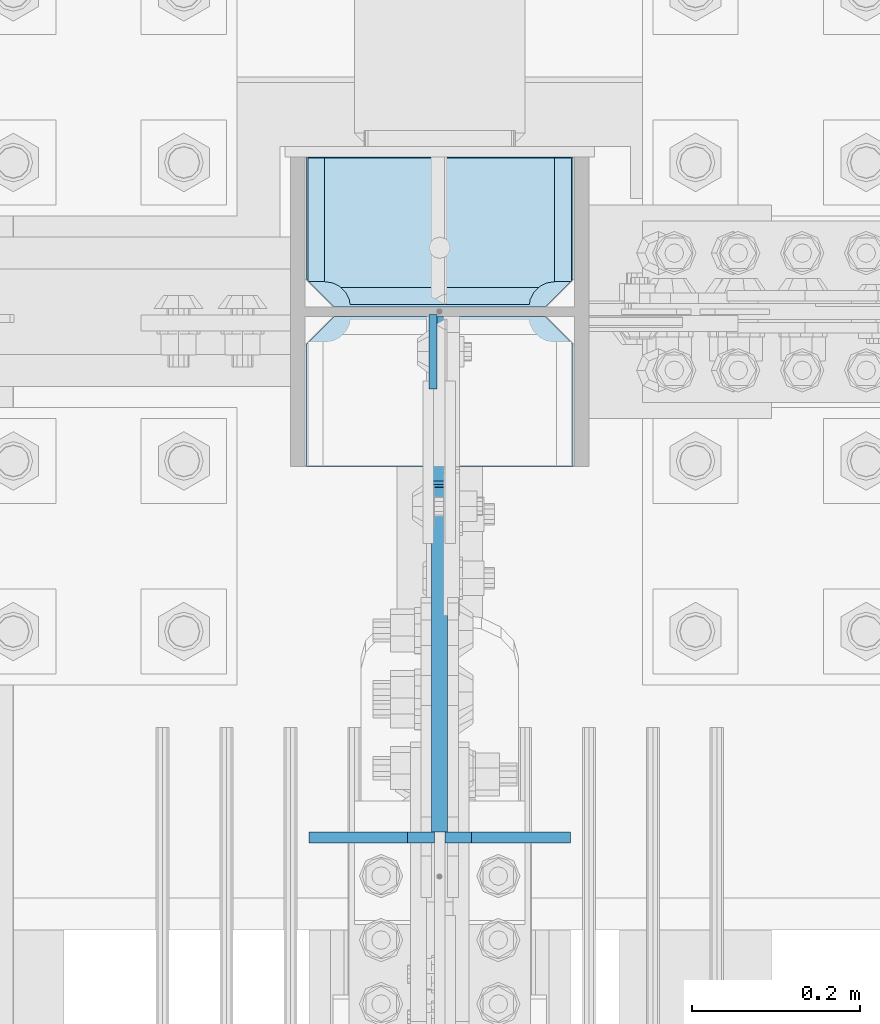
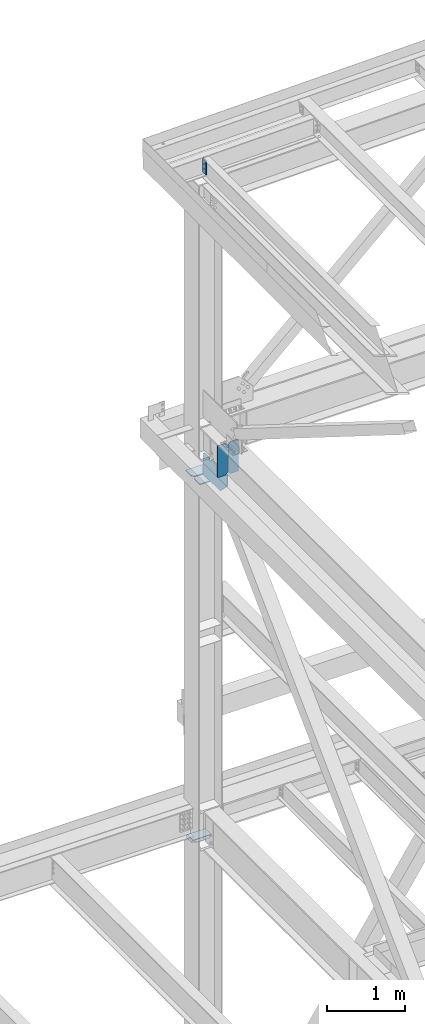
# One storey, part 3536 of 3843: 7 plates, 3 elements without a shape of their own.
"""IFC2X3 building model written with IfcOpenShell, lengths in millimetres."""

from ifc_helpers import new_model, si_unit, frame, origin_with_axes, place, context, subcontext, project, spatial, faceted_brep, material, type_object, element, aggregate, save


model = new_model("IFC2X3")

# Units and contexts
model_context = context("Model", 3, precision=1e-05, world=origin_with_axes())
body_context = subcontext(model_context, "Body", "Model", "MODEL_VIEW")
ifc_project = project(units=[si_unit("LENGTHUNIT", "METRE", prefix="MILLI"), si_unit("AREAUNIT", "SQUARE_METRE"), si_unit("VOLUMEUNIT", "CUBIC_METRE"), si_unit("MASSUNIT", "GRAM", prefix="KILO"), si_unit("TIMEUNIT", "SECOND"), si_unit("PLANEANGLEUNIT", "RADIAN"), si_unit("SOLIDANGLEUNIT", "STERADIAN"), si_unit("THERMODYNAMICTEMPERATUREUNIT", "DEGREE_CELSIUS"), si_unit("LUMINOUSINTENSITYUNIT", "LUMEN")], contexts=[model_context])

# Site, building, storey
site_placement = place(None, origin_with_axes())
site = spatial("IfcSite", under=ifc_project, at=site_placement, CompositionType="ELEMENT")
building_placement = place(site_placement, origin_with_axes())
building = spatial("IfcBuilding", under=site, at=building_placement, Name="Undefined", CompositionType="ELEMENT")
storey_placement = place(building_placement, origin_with_axes())
storey = spatial("IfcBuildingStorey", under=building, at=storey_placement, Name="Undefined", CompositionType="ELEMENT", Elevation=0.0)

# Assembly, plate
assembly_1_placement = place(storey_placement, origin_with_axes())
assembly_1 = element("IfcElementAssembly", 1, at=assembly_1_placement, inside=storey, Name="BEAM", AssemblyPlace="NOTDEFINED", PredefinedType="RIGID_FRAME")
ifc_material = material(Name="STEEL/A572-50")
plate_type_1 = type_object("IfcPlateType", PredefinedType="NOTDEFINED")
plate_1_placement = place(assembly_1_placement, frame((77004.8625000099, 104555.925, 46547.009193346), z_axis=(0.0, -1.0, 0.0), x_axis=(0.0, 0.0, -1.0)))
plate_1 = element("IfcPlate", 2, at=plate_1_placement, type_object=plate_type_1, material=ifc_material, Name="PLATE", context=body_context, shape_type="Brep", body=[
    faceted_brep([(0.0, -4.76249999999709, 0.0), (0.0, -4.76249999999709, 88.9000015258789), (0.0, 4.76249999999709, 88.9000015258789), (0.0, 4.76249999999709, 0.0), (228.600006102781, -4.7625000004191, 88.9000015257589), (228.600006102781, 4.76249999954598, 88.9000015257443), (228.600006103079, -4.7625000004482, 7.27595761418343e-12), (228.600006103079, 4.76249999954598, -7.27595761418343e-12)], [[[0, 1, 2, 3]], [[1, 4, 5, 2]], [[4, 6, 7, 5]], [[6, 0, 3, 7]], [[5, 7, 3, 2]], [[6, 4, 1, 0]]]),
])
aggregate(assembly_1, [plate_1])

# Assembly, plates
assembly_2_placement = place(storey_placement, origin_with_axes())
assembly_2 = element("IfcElementAssembly", 3, at=assembly_2_placement, inside=storey, Name="BEAM", AssemblyPlace="NOTDEFINED", PredefinedType="RIGID_FRAME")
plate_type_2 = type_object("IfcPlateType", PredefinedType="NOTDEFINED")
plate_2_placement = place(assembly_2_placement, frame((77168.375, 103932.732981873, 41948.1), z_axis=(0.0, 0.0, 1.0), x_axis=(-1.0, 0.0, 0.0)))
plate_2 = element("IfcPlate", 4, at=plate_2_placement, type_object=plate_type_2, material=ifc_material, Name="PLATE", context=body_context, shape_type="Brep", body=[
    faceted_brep([(0.0, -6.3499999046162, 0.0), (0.0, -6.35000000000582, 498.474999999999), (0.0, 6.35000000000582, 498.474999999999), (7.27595761418343e-12, 6.3499999046162, 0.0), (117.474999999991, -6.35000000000582, 498.474999999999), (117.474999999991, 6.35000000000582, 498.474999999999), (149.224999999991, -6.35000000000582, 466.724999999999), (149.224999999991, 6.35000000000582, 466.724999999999), (149.224999999991, -6.35000000000582, 31.75), (149.224999999991, 6.35000000000582, 31.75), (117.474999999991, -6.35000000000582, 0.0), (117.474999999991, 6.35000000000582, 0.0)], [[[0, 1, 2, 3]], [[1, 4, 5, 2]], [[4, 6, 7, 5]], [[6, 8, 9, 7]], [[8, 10, 11, 9]], [[10, 0, 3, 11]], [[5, 7, 9, 11, 3, 2]], [[10, 8, 6, 4, 1, 0]]]),
])
plate_3_placement = place(assembly_2_placement, frame((77006.45, 103932.732981873, 41948.1), z_axis=(0.0, 0.0, 1.0), x_axis=(-1.0, 0.0, 0.0)))
plate_3 = element("IfcPlate", 5, at=plate_3_placement, type_object=plate_type_2, material=ifc_material, Name="PLATE", context=body_context, shape_type="Brep", body=[
    faceted_brep([(0.0, -6.35000000000582, 31.75), (0.0, -6.35000000000582, 466.724999999999), (0.0, 6.35000000000582, 466.724999999999), (0.0, 6.35000000000582, 31.75), (31.75, -6.35000000000582, 498.474999999999), (31.75, 6.35000000000582, 498.474999999999), (149.224999999991, -6.35000000000582, 498.474999999999), (149.224999999991, 6.35000000000582, 498.474999999999), (149.224999999991, -6.35000000000582, 0.0), (149.224999999991, 6.35000000000582, 0.0), (31.75, -6.35000000000582, 0.0), (31.75, 6.35000000000582, 0.0)], [[[0, 1, 2, 3]], [[1, 4, 5, 2]], [[4, 6, 7, 5]], [[6, 8, 9, 7]], [[8, 10, 11, 9]], [[10, 0, 3, 11]], [[5, 7, 9, 11, 3, 2]], [[10, 8, 6, 4, 1, 0]]]),
])
aggregate(assembly_2, [plate_2, plate_3])

assembly_3_placement = place(storey_placement, origin_with_axes())
assembly_3 = element("IfcElementAssembly", 6, at=assembly_3_placement, inside=storey, Name="COLUMN", AssemblyPlace="NOTDEFINED", PredefinedType="RIGID_FRAME")
plate_type_3 = type_object("IfcPlateType", PredefinedType="NOTDEFINED")
plate_4_placement = place(assembly_3_placement, frame((77171.55, 104564.65625, 41570.3512645812), z_axis=(0.0, 1.0, 0.0), x_axis=(-1.0, 0.0, 0.0)))
plate_4 = element("IfcPlate", 7, at=plate_4_placement, type_object=plate_type_3, material=ifc_material, Name="CB_COL", context=body_context, shape_type="Brep", body=[
    faceted_brep([(0.0, -6.34999999999854, 33.3375015258789), (0.0, -6.34999999999854, 178.59375), (0.0, 6.34999999999854, 178.59375), (0.0, 6.34999999999854, 33.3375015258789), (317.499999999985, -6.34999999999854, 178.59375), (317.499999999985, 6.34999999999854, 178.59375), (317.499999999985, -6.34999999999854, 33.3375015258789), (317.499999999985, 6.34999999999854, 33.3375015258789), (284.162498474107, -6.34999999999854, 0.0), (284.162498474107, 6.34999999999854, 0.0), (33.3375015258789, -6.34999999999854, 0.0), (33.3375015258789, 6.34999999999854, 0.0)], [[[0, 1, 2, 3]], [[1, 4, 5, 2]], [[4, 6, 7, 5]], [[6, 8, 9, 7]], [[8, 10, 11, 9]], [[10, 0, 3, 11]], [[5, 7, 9, 11, 3, 2]], [[10, 8, 6, 4, 1, 0]]]),
])
plate_5_placement = place(assembly_3_placement, frame((77171.55, 104553.54375, 41570.3512645812), z_axis=(0.0, -1.0, 0.0), x_axis=(-1.0, 0.0, 0.0)))
plate_5 = element("IfcPlate", 8, at=plate_5_placement, type_object=plate_type_3, material=ifc_material, Name="CB_COL", context=body_context, shape_type="Brep", body=[
    faceted_brep([(0.0, -6.34999999999854, 33.3375015258789), (0.0, -6.34999999999854, 178.59375), (0.0, 6.34999999999854, 178.59375), (0.0, 6.34999999999854, 33.3375015258789), (317.499999999985, -6.34999999999854, 178.59375), (317.499999999985, 6.34999999999854, 178.59375), (317.499999999985, -6.34999999999854, 33.3375015258789), (317.499999999985, 6.34999999999854, 33.3375015258789), (284.162498474107, -6.34999999999854, 0.0), (284.162498474107, 6.34999999999854, 0.0), (33.3375015258789, -6.34999999999854, 0.0), (33.3375015258789, 6.34999999999854, 0.0)], [[[0, 1, 2, 3]], [[1, 4, 5, 2]], [[4, 6, 7, 5]], [[6, 8, 9, 7]], [[8, 10, 11, 9]], [[10, 0, 3, 11]], [[5, 7, 9, 11, 3, 2]], [[10, 8, 6, 4, 1, 0]]]),
])
plate_type_4 = type_object("IfcPlateType", PredefinedType="NOTDEFINED")
plate_6_placement = place(assembly_3_placement, frame((76852.4625, 104564.65625, 35831.4625), z_axis=(1.0, 0.0, 0.0), x_axis=(0.0, 1.0, 0.0)))
plate_6 = element("IfcPlate", 9, at=plate_6_placement, type_object=plate_type_4, material=ifc_material, Name="PLATE", context=body_context, shape_type="Brep", body=[
    faceted_brep([(17.7290728964872, 7.74676058471232, 272.460514298873), (23.3384576632816, 17.4625000000015, 278.069899065653), (23.3384576632816, 17.4625000000015, 42.6050887273159), (17.7290728964872, 7.74676058471232, 48.2144734940957), (9.3207252107095, -6.81692481475329, 52.4987406282016), (3.17449995232164, -17.4625000000015, 53.472207075858), (3.17449995232164, -17.4625000000015, 267.202780717111), (9.3207252107095, -6.81692481475329, 268.176247164767), (30.1625003814697, 17.4625000000015, 297.335542336717), (30.1625003814697, -17.4625000000015, 317.499500047677), (177.800000000001, -17.4625000000015, 317.499500047677), (177.800000000001, 17.4625000000015, 297.335542336717), (177.800000000001, 17.4625000000015, 23.338457663267), (177.800000000001, -17.4625000000015, 3.17449995230709), (30.1625003814697, -17.4625000000015, 3.17449995230709), (30.1625003814697, 17.4625000000015, 23.338457663267), (9.3207252107095, -17.4625000000015, 268.176247164767), (17.7290728964872, -17.4625000000015, 272.460514298873), (24.4019754014444, -17.4625000000015, 279.133416803816), (24.4019754014444, 17.4625000000015, 279.133416803816), (28.6862425355503, -17.4625000000015, 287.541764489608), (28.6862425355503, 17.4625000000015, 287.541764489608), (30.1625003814697, -17.4625000000015, 296.862489700317), (30.1625003814697, 17.4625000000015, 296.862489700317), (30.1625003814697, -17.4625000000015, 23.8124980926514), (30.1625003814697, 17.4625000000015, 23.8124980926514), (28.6862425355503, -17.4625000000015, 33.1332233033609), (28.6862425355503, 17.4625000000015, 33.1332233033609), (24.4019754014444, -17.4625000000015, 41.5415709891386), (24.4019754014444, 17.4625000000015, 41.5415709891386), (17.7290728964872, -17.4625000000015, 48.2144734940957), (9.3207252107095, -17.4625000000015, 52.4987406282016)], [[[0, 1, 2, 3, 4, 5, 6, 7]], [[8, 9, 10, 11]], [[12, 13, 14, 15]], [[16, 7, 6]], [[16, 17, 0, 7]], [[17, 18, 19, 1, 0]], [[18, 20, 21, 19]], [[20, 22, 23, 21]], [[23, 22, 9, 8]], [[11, 10, 13, 12]], [[24, 25, 15, 14]], [[24, 26, 27, 25]], [[26, 28, 29, 27]], [[29, 28, 30, 3, 2]], [[30, 31, 4, 3]], [[31, 5, 4]], [[19, 21, 23, 8, 11, 12, 15, 25, 27, 29, 2, 1]], [[31, 30, 28, 26, 24, 14, 13, 10, 9, 22, 20, 18, 17, 16, 6, 5]]]),
])
plate_type_5 = type_object("IfcPlateType", PredefinedType="NOTDEFINED")
plate_7_placement = place(assembly_3_placement, frame((77012.8, 103939.082981873, 41925.875), z_axis=(0.0, 0.0, -1.0), x_axis=(0.0, 1.0, 0.0)))
plate_7 = element("IfcPlate", 10, at=plate_7_placement, type_object=plate_type_5, material=ifc_material, Name="CB", context=body_context, shape_type="Brep", body=[
    faceted_brep([(461.267018126659, -9.52499999999418, 25.4000001907334), (461.267018126659, 9.52499999999418, 25.4000001907334), (461.267018126659, 9.52499999999418, 0.0), (461.267018126659, -9.52499999999418, 0.0), (460.300288204075, -9.52499999999418, 30.2600797087798), (460.300288204075, 9.52499999999418, 30.2600797087798), (457.547274303593, -9.52499999999418, 34.3802561769335), (457.547274303593, 9.52499999999418, 34.3802561769335), (453.427097835433, -9.52499999999418, 37.1332700774074), (453.427097835433, 9.52499999999418, 37.1332700774074), (448.567018317393, -9.52499999999418, 38.0999999999985), (448.567018317393, 9.52499999999418, 38.0999999999985), (423.167017935921, -9.52499999999418, 38.0999999999985), (423.167017935921, 9.52499999999418, 38.0999999999985), (418.306938417882, -9.52499999999418, 37.1332700774074), (418.306938417882, 9.52499999999418, 37.1332700774074), (414.186761949721, -9.52499999999418, 34.3802561769335), (414.186761949721, 9.52499999999418, 34.3802561769335), (411.43374804924, -9.52499999999418, 30.2600797087798), (411.43374804924, 9.52499999999418, 30.2600797087798), (410.467018126656, -9.52499999999418, 25.4000001907334), (410.467018126656, 9.52499999999418, 25.4000001907334), (410.467018126656, -9.52499999999418, 0.0), (410.467018126656, 9.52499999999418, 0.0), (0.0, -9.52500000000146, 0.0), (0.0, 9.52500000000146, 0.0), (0.0, -9.52499999999418, 171.486764635461), (0.0, 9.52499999999418, 171.486764635461), (174.807783674798, -9.52499999999418, 349.173735418757), (174.807783674798, 9.52499999999418, 349.173735418757), (595.410768889589, -9.52499999999418, 349.173735418757), (595.410768889589, 9.52499999999418, 349.173735418757), (614.46076812665, -9.52499999999418, 330.123736181697), (614.46076812665, 9.52499999999418, 330.123736181697), (614.46076812665, -9.52499999999418, 19.0500000000102), (614.46076812665, 9.52499999999418, 19.0500000000102), (595.410768126632, 9.52499999999418, 0.0), (595.410768126632, -9.52499999999418, 0.0)], [[[0, 1, 2, 3]], [[4, 5, 1, 0]], [[6, 7, 5, 4]], [[8, 9, 7, 6]], [[10, 11, 9, 8]], [[12, 13, 11, 10]], [[14, 15, 13, 12]], [[16, 17, 15, 14]], [[18, 19, 17, 16]], [[20, 21, 19, 18]], [[22, 23, 21, 20]], [[24, 25, 23, 22]], [[24, 26, 27, 25]], [[26, 28, 29, 27]], [[28, 30, 31, 29]], [[30, 32, 33, 31]], [[33, 32, 34, 35]], [[2, 1, 5, 7, 9, 11, 13, 15, 17, 19, 21, 23, 25, 27, 29, 31, 33, 35, 36]], [[3, 2, 36, 37]], [[32, 30, 28, 26, 24, 22, 20, 18, 16, 14, 12, 10, 8, 6, 4, 0, 3, 37, 34]], [[36, 35, 34, 37]]]),
])
aggregate(assembly_3, [plate_6, plate_4, plate_5, plate_7])

save(model, "model.ifc")
